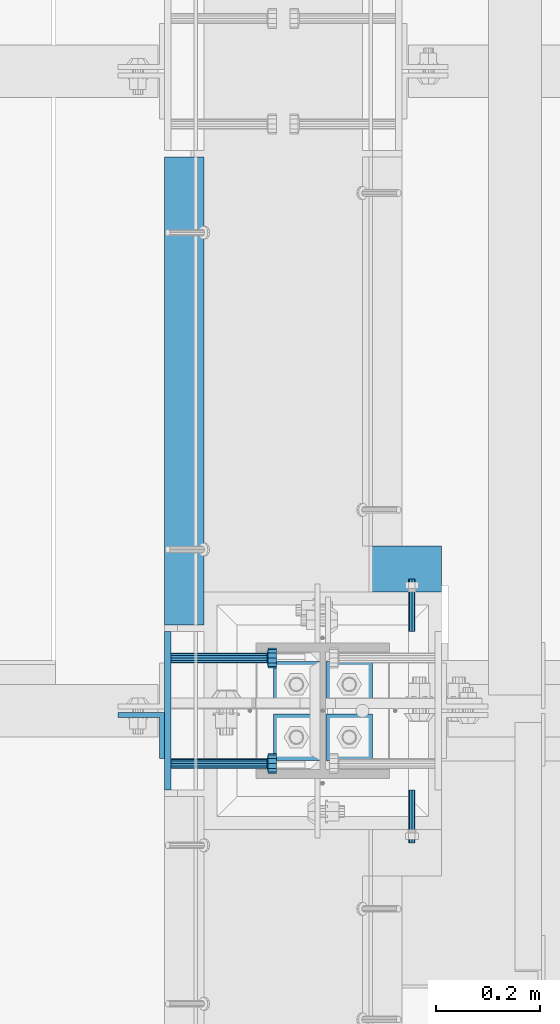
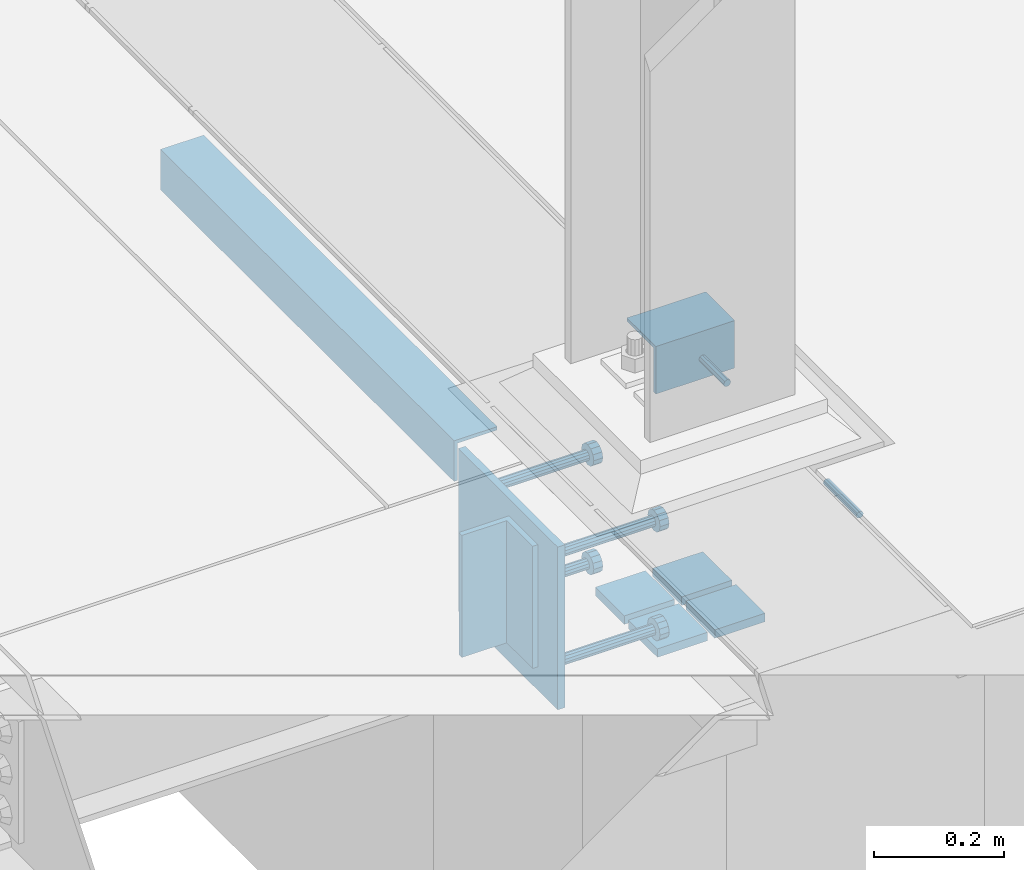
# One storey, part 2051 of 3843: 14 beams, 7 elements without a shape of their own.
"""IFC2X3 building model written with IfcOpenShell, lengths in millimetres."""

from ifc_helpers import new_model, si_unit, frame, origin_with_axes, place, context, subcontext, project, spatial, faceted_brep, material, type_object, element, aggregate, save


model = new_model("IFC2X3")

# Units and contexts
model_context = context("Model", 3, precision=1e-05, world=origin_with_axes())
body_context = subcontext(model_context, "Body", "Model", "MODEL_VIEW")
ifc_project = project(units=[si_unit("LENGTHUNIT", "METRE", prefix="MILLI"), si_unit("AREAUNIT", "SQUARE_METRE"), si_unit("VOLUMEUNIT", "CUBIC_METRE"), si_unit("MASSUNIT", "GRAM", prefix="KILO"), si_unit("TIMEUNIT", "SECOND"), si_unit("PLANEANGLEUNIT", "RADIAN"), si_unit("SOLIDANGLEUNIT", "STERADIAN"), si_unit("THERMODYNAMICTEMPERATUREUNIT", "DEGREE_CELSIUS"), si_unit("LUMINOUSINTENSITYUNIT", "LUMEN")], contexts=[model_context])

# Site, building, storey
site_placement = place(None, origin_with_axes())
site = spatial("IfcSite", under=ifc_project, at=site_placement, CompositionType="ELEMENT")
building_placement = place(site_placement, origin_with_axes())
building = spatial("IfcBuilding", under=site, at=building_placement, Name="Undefined", CompositionType="ELEMENT")
storey_placement = place(building_placement, origin_with_axes())
storey = spatial("IfcBuildingStorey", under=building, at=storey_placement, Name="Undefined", CompositionType="ELEMENT", Elevation=0.0)

# Assembly, beam
assembly_1_placement = place(storey_placement, origin_with_axes())
assembly_1 = element("IfcElementAssembly", 1, at=assembly_1_placement, inside=storey, Name="GRATING", AssemblyPlace="NOTDEFINED", PredefinedType="NOTDEFINED")
ifc_material_1 = material(Name="STEEL/A36")
beam_type_1 = type_object("IfcBeamType", Name="L3-1/2X3-1/2X1/4", PredefinedType="NOTDEFINED")
beam_1_placement = place(assembly_1_placement, frame((62725.3000467757, 15271.7501304977, 30384.7500045776), z_axis=(0.0, 0.0, -1.0), x_axis=(1.0, 0.0, 0.0)))
beam_1 = element("IfcBeam", 2, at=beam_1_placement, type_object=beam_type_1, material=ifc_material_1, Name="ANGLE", ObjectType="L3-1/2X3-1/2X1/4", context=body_context, shape_type="Brep", body=[
    faceted_brep([(-3.63797880709171e-12, 44.4499999999971, -44.4500000000007), (-3.63797880709171e-12, 44.4499999999971, 44.4500000000007), (139.699994826158, 44.4499999999043, 44.4500000000007), (139.699994826158, 44.4499999999043, -44.4500000000007), (-3.63797880709171e-11, 38.1000000000149, 44.4500000000007), (139.699994826165, 38.0999999999021, 44.4500000000007), (0.0, 38.0999999999985, -38.0999999999985), (139.699999999997, 38.0999999999985, -38.0999999999985), (4.36557456851006e-11, -44.4500000000226, -38.0999999999985), (139.699994826253, -44.4500000001353, -38.0999999999985), (3.63797880709171e-12, -44.4499999999971, -44.4500000000007), (139.699994826253, -44.4500000001353, -44.4500000000007)], [[[0, 1, 2, 3]], [[1, 4, 5, 2]], [[4, 6, 7, 5]], [[6, 8, 9, 7]], [[8, 10, 11, 9]], [[10, 0, 3, 11]], [[5, 7, 9, 11, 3, 2]], [[10, 8, 6, 4, 1, 0]]]),
])
aggregate(assembly_1, [beam_1])

assembly_2_placement = place(storey_placement, origin_with_axes())
assembly_2 = element("IfcElementAssembly", 3, at=assembly_2_placement, inside=storey, Name="EPOXY BOLT", AssemblyPlace="NOTDEFINED", PredefinedType="RIGID_FRAME")
ifc_material_2 = material(Name="STEEL/A307")
beam_type_2 = type_object("IfcBeamType", PredefinedType="NOTDEFINED")
beam_2_placement = place(assembly_2_placement, frame((62807.8501800578, 15252.7000607682, 30378.4), z_axis=(0.0, 0.0, -1.0), x_axis=(0.0, -1.0, 0.0)))
beam_2 = element("IfcBeam", 4, at=beam_2_placement, type_object=beam_type_2, material=ifc_material_2, Name="EPOXY BOLT", context=body_context, shape_type="Brep", body=[
    faceted_brep([(0.0, -6.3499999046162, 0.0), (0.0, -4.49012806053361, -4.49012806053361), (101.6, -4.49012806053361, -4.49012806053361), (101.6, -6.34999999999854, 0.0), (7.27595761418343e-12, -1.81898940354586e-12, -6.34999990463257), (101.6, 0.0, -6.34999999999854), (0.0, 4.49012806053361, -4.49012806053361), (101.6, 4.49012806053361, -4.49012806053361), (7.27595761418343e-12, 6.3499999046162, 0.0), (101.6, 6.34999999999854, 0.0), (0.0, 4.49012806053361, 4.49012806053361), (101.6, 4.49012806053361, 4.49012806053361), (7.27595761418343e-12, -1.81898940354586e-12, 6.34999990463257), (101.6, 0.0, 6.34999999999854), (0.0, -4.49012806053361, 4.49012806053361), (101.6, -4.49012806053361, 4.49012806053361)], [[[0, 1, 2, 3]], [[1, 4, 5, 2]], [[4, 6, 7, 5]], [[6, 8, 9, 7]], [[8, 10, 11, 9]], [[10, 12, 13, 11]], [[12, 14, 15, 13]], [[14, 0, 3, 15]], [[5, 7, 9, 11, 13, 15, 3, 2]], [[14, 12, 10, 8, 6, 4, 1, 0]]]),
])
aggregate(assembly_2, [beam_2])

assembly_3_placement = place(storey_placement, origin_with_axes())
assembly_3 = element("IfcElementAssembly", 5, at=assembly_3_placement, inside=storey, Name="EPOXY BOLT", AssemblyPlace="NOTDEFINED", PredefinedType="RIGID_FRAME")
beam_3_placement = place(assembly_3_placement, frame((62807.8501800578, 14744.6999392318, 30378.4), z_axis=(0.0, 0.0, -1.0), x_axis=(0.0, 1.0, 0.0)))
beam_3 = element("IfcBeam", 6, at=beam_3_placement, type_object=beam_type_2, material=ifc_material_2, Name="EPOXY BOLT", context=body_context, shape_type="Brep", body=[
    faceted_brep([(0.0, -6.3499999046162, 0.0), (0.0, -4.49012806053361, -4.49012806053361), (101.6, -4.49012806053361, -4.49012806053361), (101.6, -6.34999999999854, 0.0), (7.27595761418343e-12, -1.81898940354586e-12, -6.34999990463257), (101.6, 0.0, -6.34999999999854), (0.0, 4.49012806053361, -4.49012806053361), (101.6, 4.49012806053361, -4.49012806053361), (7.27595761418343e-12, 6.3499999046162, 0.0), (101.6, 6.34999999999854, 0.0), (0.0, 4.49012806053361, 4.49012806053361), (101.6, 4.49012806053361, 4.49012806053361), (7.27595761418343e-12, -1.81898940354586e-12, 6.34999990463257), (101.6, 0.0, 6.34999999999854), (0.0, -4.49012806053361, 4.49012806053361), (101.6, -4.49012806053361, 4.49012806053361)], [[[0, 1, 2, 3]], [[1, 4, 5, 2]], [[4, 6, 7, 5]], [[6, 8, 9, 7]], [[8, 10, 11, 9]], [[10, 12, 13, 11]], [[12, 14, 15, 13]], [[14, 0, 3, 15]], [[5, 7, 9, 11, 13, 15, 3, 2]], [[14, 12, 10, 8, 6, 4, 1, 0]]]),
])
aggregate(assembly_3, [beam_3])

assembly_4_placement = place(storey_placement, origin_with_axes())
assembly_4 = element("IfcElementAssembly", 7, at=assembly_4_placement, inside=storey, Name="EMBED PLATE", AssemblyPlace="NOTDEFINED", PredefinedType="RIGID_FRAME")
beam_type_3 = type_object("IfcBeamType", PredefinedType="NOTDEFINED")
beam_4_placement = place(assembly_4_placement, frame((62337.9499969482, 14998.7, 30422.85), z_axis=(0.0, -1.0, 0.0), x_axis=(0.0, 0.0, -1.0)))
beam_4 = element("IfcBeam", 8, at=beam_4_placement, type_object=beam_type_3, material=ifc_material_1, Name="EMBED PLATE", context=body_context, shape_type="Brep", body=[
    faceted_brep([(-1.0550138540566e-10, 6.34999999999854, -152.400000000664), (1.0550138540566e-10, 6.34999999999854, 152.400000000656), (304.799999999999, 6.34999999999854, 152.400000000001), (304.799999999999, 6.34999999999854, -152.400000000001), (1.0550138540566e-10, -6.34999999999854, 152.400000000656), (304.799999999999, -6.34999999999854, 152.400000000001), (-1.0550138540566e-10, -6.34999999999854, -152.400000000664), (304.799999999999, -6.34999999999854, -152.400000000001)], [[[0, 1, 2, 3]], [[1, 4, 5, 2]], [[4, 6, 7, 5]], [[6, 0, 3, 7]], [[5, 7, 3, 2]], [[6, 4, 1, 0]]]),
])

assembly_5_placement = place(storey_placement, origin_with_axes())
assembly_5 = element("IfcElementAssembly", 9, at=assembly_5_placement, inside=storey, Name="ANGLE", AssemblyPlace="NOTDEFINED", PredefinedType="RIGID_FRAME")
beam_type_4 = type_object("IfcBeamType", Name="L3X3X1/4", PredefinedType="NOTDEFINED")
beam_5_placement = place(assembly_5_placement, frame((62369.7000040825, 16063.9120001143, 30391.1000045777), z_axis=(0.0, 0.0, -1.0), x_axis=(0.0, -1.0, 0.0)))
beam_5 = element("IfcBeam", 10, at=beam_5_placement, type_object=beam_type_4, material=ifc_material_1, Name="ANGLE", ObjectType="L3X3X1/4", context=body_context, shape_type="Brep", body=[
    faceted_brep([(0.0, 38.0999999999985, -38.0999999999985), (0.0, 38.0999999999985, 38.0999999999985), (900.112000000037, 38.1000000023996, 38.0999999999985), (900.112000000037, 38.1000000023996, -38.0999999999985), (0.0, 31.75, 38.0999999999985), (900.11200000003, 31.7500000023938, 38.0999999999985), (0.0, 31.75, -31.75), (900.11200000003, 31.7500000023938, -31.75), (0.0, -38.0999999999985, -31.75), (900.111999999965, -38.0999999976048, -31.75), (0.0, -38.0999999999985, -38.0999999999985), (900.111999999965, -38.0999999976048, -38.0999999999985)], [[[0, 1, 2, 3]], [[1, 4, 5, 2]], [[4, 6, 7, 5]], [[6, 8, 9, 7]], [[8, 10, 11, 9]], [[10, 0, 3, 11]], [[5, 7, 9, 11, 3, 2]], [[10, 8, 6, 4, 1, 0]]]),
])
aggregate(assembly_5, [beam_5])

# Assembly, beams
assembly_6_placement = place(storey_placement, origin_with_axes())
assembly_6 = element("IfcElementAssembly", 11, at=assembly_6_placement, inside=storey, Name="TEMPLATE", AssemblyPlace="NOTDEFINED", PredefinedType="RIGID_FRAME")
ifc_material_3 = material(Name="STEEL/A572-50")
beam_type_5 = type_object("IfcBeamType", PredefinedType="NOTDEFINED")
beam_6_placement = place(assembly_6_placement, frame((62585.6, 14903.45, 30116.4625), z_axis=(1.0, 0.0, 0.0), x_axis=(0.0, 1.0, 0.0)))
beam_6 = element("IfcBeam", 12, at=beam_6_placement, type_object=beam_type_5, material=ifc_material_3, context=body_context, shape_type="Brep", body=[
    faceted_brep([(0.0, 7.9375, -44.4499999999971), (0.0, 7.9375, 44.4499999999971), (88.8999999999942, 7.9375, 44.4499999999971), (88.8999999999942, 7.9375, -44.4499999999971), (0.0, -7.9375, 44.4499999999971), (88.8999999999942, -7.9375, 44.4499999999971), (0.0, -7.9375, -44.4499999999971), (88.8999999999942, -7.9375, -44.4499999999971)], [[[0, 1, 2, 3]], [[1, 4, 5, 2]], [[4, 6, 7, 5]], [[6, 0, 3, 7]], [[5, 7, 3, 2]], [[6, 4, 1, 0]]]),
])
beam_7_placement = place(assembly_6_placement, frame((62687.2, 14903.45, 30116.4625), z_axis=(1.0, 0.0, 0.0), x_axis=(0.0, 1.0, 0.0)))
beam_7 = element("IfcBeam", 13, at=beam_7_placement, type_object=beam_type_5, material=ifc_material_3, context=body_context, shape_type="Brep", body=[
    faceted_brep([(0.0, 7.9375, -44.4499999999971), (0.0, 7.9375, 44.4499999999971), (88.8999999999942, 7.9375, 44.4499999999971), (88.8999999999942, 7.9375, -44.4499999999971), (0.0, -7.9375, 44.4499999999971), (88.8999999999942, -7.9375, 44.4499999999971), (0.0, -7.9375, -44.4499999999971), (88.8999999999942, -7.9375, -44.4499999999971)], [[[0, 1, 2, 3]], [[1, 4, 5, 2]], [[4, 6, 7, 5]], [[6, 0, 3, 7]], [[5, 7, 3, 2]], [[6, 4, 1, 0]]]),
])
beam_8_placement = place(assembly_6_placement, frame((62585.6, 15005.05, 30116.4625), z_axis=(1.0, 0.0, 0.0), x_axis=(0.0, 1.0, 0.0)))
beam_8 = element("IfcBeam", 14, at=beam_8_placement, type_object=beam_type_5, material=ifc_material_3, context=body_context, shape_type="Brep", body=[
    faceted_brep([(0.0, 7.9375, -44.4499999999971), (0.0, 7.9375, 44.4499999999971), (88.8999999999942, 7.9375, 44.4499999999971), (88.8999999999942, 7.9375, -44.4499999999971), (0.0, -7.9375, 44.4499999999971), (88.8999999999942, -7.9375, 44.4499999999971), (0.0, -7.9375, -44.4499999999971), (88.8999999999942, -7.9375, -44.4499999999971)], [[[0, 1, 2, 3]], [[1, 4, 5, 2]], [[4, 6, 7, 5]], [[6, 0, 3, 7]], [[5, 7, 3, 2]], [[6, 4, 1, 0]]]),
])
beam_9_placement = place(assembly_6_placement, frame((62687.2, 15005.05, 30116.4625), z_axis=(1.0, 0.0, 0.0), x_axis=(0.0, 1.0, 0.0)))
beam_9 = element("IfcBeam", 15, at=beam_9_placement, type_object=beam_type_5, material=ifc_material_3, context=body_context, shape_type="Brep", body=[
    faceted_brep([(0.0, 7.9375, -44.4499999999971), (0.0, 7.9375, 44.4499999999971), (88.8999999999942, 7.9375, 44.4499999999971), (88.8999999999942, 7.9375, -44.4499999999971), (0.0, -7.9375, 44.4499999999971), (88.8999999999942, -7.9375, 44.4499999999971), (0.0, -7.9375, -44.4499999999971), (88.8999999999942, -7.9375, -44.4499999999971)], [[[0, 1, 2, 3]], [[1, 4, 5, 2]], [[4, 6, 7, 5]], [[6, 0, 3, 7]], [[5, 7, 3, 2]], [[6, 4, 1, 0]]]),
])
aggregate(assembly_6, [beam_6, beam_7, beam_8, beam_9])

# Assembly, beam
assembly_7_placement = place(storey_placement, origin_with_axes())
assembly_7 = element("IfcElementAssembly", 16, at=assembly_7_placement, inside=storey, Name="BEAM", AssemblyPlace="NOTDEFINED", PredefinedType="RIGID_FRAME")
beam_type_6 = type_object("IfcBeamType", Name="L3-1/2X3-1/2X3/8", PredefinedType="NOTDEFINED")
beam_10_placement = place(assembly_7_placement, frame((62287.1499969482, 14951.075, 30391.1), z_axis=(0.0, -1.0, 0.0), x_axis=(0.0, 0.0, -1.0)))
beam_10 = element("IfcBeam", 17, at=beam_10_placement, type_object=beam_type_6, material=ifc_material_1, Name="ANGLE", ObjectType="L3-1/2X3-1/2X3/8", context=body_context, shape_type="Brep", body=[
    faceted_brep([(-3.63797880709171e-12, 44.4499999999971, -44.4500000000007), (-3.63797880709171e-12, 44.4499999999971, 44.4500000000007), (228.600000000006, 44.4499999999971, 44.4500000000007), (228.600000000006, 44.4499999999971, -44.4500000000007), (0.0, 34.9250000000029, 44.4500000000007), (228.600000000006, 34.9250000000029, 44.4500000000007), (0.0, 34.9250000000029, -34.9250000000029), (228.600000000006, 34.9250000000029, -34.9249999999993), (0.0, -44.4499999999971, -34.9249999999993), (228.600000000006, -44.4499999999971, -34.9249999999993), (3.63797880709171e-12, -44.4499999999971, -44.4500000000007), (228.600000000006, -44.4499999999971, -44.4500000000007)], [[[0, 1, 2, 3]], [[1, 4, 5, 2]], [[4, 6, 7, 5]], [[6, 8, 9, 7]], [[8, 10, 11, 9]], [[10, 0, 3, 11]], [[5, 7, 9, 11, 3, 2]], [[10, 8, 6, 4, 1, 0]]]),
])
aggregate(assembly_7, [beam_10])

# Beam
ifc_material_4 = material(Name="STEEL/A108")
beam_type_7 = type_object("IfcBeamType", PredefinedType="NOTDEFINED")
beam_11_placement = place(assembly_4_placement, frame((62344.2999969482, 15100.3, 30372.05), z_axis=(0.0, 1.0, 0.0), x_axis=(1.0, 0.0, 0.0)))
beam_11 = element("IfcBeam", 18, at=beam_11_placement, type_object=beam_type_7, material=ifc_material_4, Name="HEADED STUD ANCHOR", context=body_context, shape_type="Brep", body=[
    faceted_brep([(0.0, -9.52000045776367, 0.0), (0.0, -8.25, -4.76000022888184), (184.912000000004, -8.25, -4.76000022888184), (184.912000000004, -9.52000045776367, 0.0), (0.0, -4.76000022888184, -8.25), (184.912000000004, -4.76000022888184, -8.25), (0.0, 0.0, -9.52000045776367), (184.912000000004, 0.0, -9.52000045776367), (0.0, 4.76000022888184, -8.25), (184.912000000004, 4.76000022888184, -8.25), (0.0, 8.25, -4.76000022888184), (184.912000000004, 8.25, -4.76000022888184), (0.0, 9.52000045776367, 0.0), (184.912000000004, 9.52000045776367, 0.0), (0.0, 8.25, 4.76000022888184), (184.912000000004, 8.25, 4.76000022888184), (0.0, 4.76000022888184, 8.25), (184.912000000004, 4.76000022888184, 8.25), (0.0, 0.0, 9.52000045776367), (184.912000000004, 0.0, 9.52000045776367), (0.0, -4.76000022888184, 8.25), (184.912000000004, -4.76000022888184, 8.25), (0.0, -8.25, 4.76000022888184), (184.912000000004, -8.25, 4.76000022888184), (186.944000000003, -16.5, -9.52000045776367), (186.944000000003, -19.0499992370605, 0.0), (186.944000000003, -9.52000045776367, -16.5), (186.944000000003, 0.0, -19.0499992370605), (186.944000000003, 9.52000045776367, -16.5), (186.944000000003, 16.5, -9.52000045776367), (186.944000000003, 19.0499992370605, 0.0), (186.944000000003, 16.5, 9.52000045776367), (186.944000000003, 9.52000045776367, 16.5), (186.944000000003, 0.0, 19.0499992370605), (186.944000000003, -9.52000045776367, 16.5), (186.944000000003, -16.5, 9.52000045776367), (203.199999999997, -16.5, -9.52000045776367), (203.199999999997, -19.0499992370605, 0.0), (203.199999999997, -9.52000045776367, -16.5), (203.199999999997, 0.0, -19.0499992370605), (203.199999999997, 9.52000045776367, -16.5), (203.199999999997, 16.5, -9.52000045776367), (203.199999999997, 19.0499992370605, 0.0), (203.199999999997, 16.5, 9.52000045776367), (203.199999999997, 9.52000045776367, 16.5), (203.199999999997, 0.0, 19.0499992370605), (203.199999999997, -9.52000045776367, 16.5), (203.199999999997, -16.5, 9.52000045776367)], [[[0, 1, 2, 3]], [[1, 4, 5, 2]], [[4, 6, 7, 5]], [[6, 8, 9, 7]], [[8, 10, 11, 9]], [[10, 12, 13, 11]], [[12, 14, 15, 13]], [[14, 16, 17, 15]], [[16, 18, 19, 17]], [[18, 20, 21, 19]], [[20, 22, 23, 21]], [[22, 0, 3, 23]], [[22, 20, 18, 16, 14, 12, 10, 8, 6, 4, 1, 0]], [[3, 2, 24, 25]], [[2, 5, 26, 24]], [[5, 7, 27, 26]], [[7, 9, 28, 27]], [[9, 11, 29, 28]], [[11, 13, 30, 29]], [[13, 15, 31, 30]], [[15, 17, 32, 31]], [[17, 19, 33, 32]], [[19, 21, 34, 33]], [[21, 23, 35, 34]], [[23, 3, 25, 35]], [[25, 24, 36, 37]], [[24, 26, 38, 36]], [[26, 27, 39, 38]], [[27, 28, 40, 39]], [[28, 29, 41, 40]], [[29, 30, 42, 41]], [[30, 31, 43, 42]], [[31, 32, 44, 43]], [[32, 33, 45, 44]], [[33, 34, 46, 45]], [[34, 35, 47, 46]], [[35, 25, 37, 47]], [[38, 39, 40, 41, 42, 43, 44, 45, 46, 47, 37, 36]]]),
])

beam_12_placement = place(assembly_4_placement, frame((62344.2999969482, 15100.3, 30168.85), z_axis=(0.0, 1.0, 0.0), x_axis=(1.0, 0.0, 0.0)))
beam_12 = element("IfcBeam", 19, at=beam_12_placement, type_object=beam_type_7, material=ifc_material_4, Name="HEADED STUD ANCHOR", context=body_context, shape_type="Brep", body=[
    faceted_brep([(0.0, -9.52000045776367, 0.0), (0.0, -8.25, -4.76000022888184), (184.912000000004, -8.25, -4.76000022888184), (184.912000000004, -9.52000045776367, 0.0), (0.0, -4.76000022888184, -8.25), (184.912000000004, -4.76000022888184, -8.25), (0.0, 0.0, -9.52000045776367), (184.912000000004, 0.0, -9.52000045776367), (0.0, 4.76000022888184, -8.25), (184.912000000004, 4.76000022888184, -8.25), (0.0, 8.25, -4.76000022888184), (184.912000000004, 8.25, -4.76000022888184), (0.0, 9.52000045776367, 0.0), (184.912000000004, 9.52000045776367, 0.0), (0.0, 8.25, 4.76000022888184), (184.912000000004, 8.25, 4.76000022888184), (0.0, 4.76000022888184, 8.25), (184.912000000004, 4.76000022888184, 8.25), (0.0, 0.0, 9.52000045776367), (184.912000000004, 0.0, 9.52000045776367), (0.0, -4.76000022888184, 8.25), (184.912000000004, -4.76000022888184, 8.25), (0.0, -8.25, 4.76000022888184), (184.912000000004, -8.25, 4.76000022888184), (186.944000000003, -16.5, -9.52000045776367), (186.944000000003, -19.0499992370605, 0.0), (186.944000000003, -9.52000045776367, -16.5), (186.944000000003, 0.0, -19.0499992370605), (186.944000000003, 9.52000045776367, -16.5), (186.944000000003, 16.5, -9.52000045776367), (186.944000000003, 19.0499992370605, 0.0), (186.944000000003, 16.5, 9.52000045776367), (186.944000000003, 9.52000045776367, 16.5), (186.944000000003, 0.0, 19.0499992370605), (186.944000000003, -9.52000045776367, 16.5), (186.944000000003, -16.5, 9.52000045776367), (203.199999999997, -16.5, -9.52000045776367), (203.199999999997, -19.0499992370605, 0.0), (203.199999999997, -9.52000045776367, -16.5), (203.199999999997, 0.0, -19.0499992370605), (203.199999999997, 9.52000045776367, -16.5), (203.199999999997, 16.5, -9.52000045776367), (203.199999999997, 19.0499992370605, 0.0), (203.199999999997, 16.5, 9.52000045776367), (203.199999999997, 9.52000045776367, 16.5), (203.199999999997, 0.0, 19.0499992370605), (203.199999999997, -9.52000045776367, 16.5), (203.199999999997, -16.5, 9.52000045776367)], [[[0, 1, 2, 3]], [[1, 4, 5, 2]], [[4, 6, 7, 5]], [[6, 8, 9, 7]], [[8, 10, 11, 9]], [[10, 12, 13, 11]], [[12, 14, 15, 13]], [[14, 16, 17, 15]], [[16, 18, 19, 17]], [[18, 20, 21, 19]], [[20, 22, 23, 21]], [[22, 0, 3, 23]], [[22, 20, 18, 16, 14, 12, 10, 8, 6, 4, 1, 0]], [[3, 2, 24, 25]], [[2, 5, 26, 24]], [[5, 7, 27, 26]], [[7, 9, 28, 27]], [[9, 11, 29, 28]], [[11, 13, 30, 29]], [[13, 15, 31, 30]], [[15, 17, 32, 31]], [[17, 19, 33, 32]], [[19, 21, 34, 33]], [[21, 23, 35, 34]], [[23, 3, 25, 35]], [[25, 24, 36, 37]], [[24, 26, 38, 36]], [[26, 27, 39, 38]], [[27, 28, 40, 39]], [[28, 29, 41, 40]], [[29, 30, 42, 41]], [[30, 31, 43, 42]], [[31, 32, 44, 43]], [[32, 33, 45, 44]], [[33, 34, 46, 45]], [[34, 35, 47, 46]], [[35, 25, 37, 47]], [[38, 39, 40, 41, 42, 43, 44, 45, 46, 47, 37, 36]]]),
])

beam_13_placement = place(assembly_4_placement, frame((62344.2999969482, 14897.1, 30372.05), z_axis=(0.0, 1.0, 0.0), x_axis=(1.0, 0.0, 0.0)))
beam_13 = element("IfcBeam", 20, at=beam_13_placement, type_object=beam_type_7, material=ifc_material_1, Name="PLATE", context=body_context, shape_type="Brep", body=[
    faceted_brep([(0.0, -9.52000045776367, 0.0), (0.0, -8.25, -4.76000022888184), (184.912000000004, -8.25, -4.76000022888184), (184.912000000004, -9.52000045776367, 0.0), (0.0, -4.76000022888184, -8.25), (184.912000000004, -4.76000022888184, -8.25), (0.0, 0.0, -9.52000045776367), (184.912000000004, 0.0, -9.52000045776367), (0.0, 4.76000022888184, -8.25), (184.912000000004, 4.76000022888184, -8.25), (0.0, 8.25, -4.76000022888184), (184.912000000004, 8.25, -4.76000022888184), (0.0, 9.52000045776367, 0.0), (184.912000000004, 9.52000045776367, 0.0), (0.0, 8.25, 4.76000022888184), (184.912000000004, 8.25, 4.76000022888184), (0.0, 4.76000022888184, 8.25), (184.912000000004, 4.76000022888184, 8.25), (0.0, 0.0, 9.52000045776367), (184.912000000004, 0.0, 9.52000045776367), (0.0, -4.76000022888184, 8.25), (184.912000000004, -4.76000022888184, 8.25), (0.0, -8.25, 4.76000022888184), (184.912000000004, -8.25, 4.76000022888184), (186.944000000003, -16.5, -9.52000045776367), (186.944000000003, -19.0499992370605, 0.0), (186.944000000003, -9.52000045776367, -16.5), (186.944000000003, 0.0, -19.0499992370605), (186.944000000003, 9.52000045776367, -16.5), (186.944000000003, 16.5, -9.52000045776367), (186.944000000003, 19.0499992370605, 0.0), (186.944000000003, 16.5, 9.52000045776367), (186.944000000003, 9.52000045776367, 16.5), (186.944000000003, 0.0, 19.0499992370605), (186.944000000003, -9.52000045776367, 16.5), (186.944000000003, -16.5, 9.52000045776367), (203.199999999997, -16.5, -9.52000045776367), (203.199999999997, -19.0499992370605, 0.0), (203.199999999997, -9.52000045776367, -16.5), (203.199999999997, 0.0, -19.0499992370605), (203.199999999997, 9.52000045776367, -16.5), (203.199999999997, 16.5, -9.52000045776367), (203.199999999997, 19.0499992370605, 0.0), (203.199999999997, 16.5, 9.52000045776367), (203.199999999997, 9.52000045776367, 16.5), (203.199999999997, 0.0, 19.0499992370605), (203.199999999997, -9.52000045776367, 16.5), (203.199999999997, -16.5, 9.52000045776367)], [[[0, 1, 2, 3]], [[1, 4, 5, 2]], [[4, 6, 7, 5]], [[6, 8, 9, 7]], [[8, 10, 11, 9]], [[10, 12, 13, 11]], [[12, 14, 15, 13]], [[14, 16, 17, 15]], [[16, 18, 19, 17]], [[18, 20, 21, 19]], [[20, 22, 23, 21]], [[22, 0, 3, 23]], [[22, 20, 18, 16, 14, 12, 10, 8, 6, 4, 1, 0]], [[3, 2, 24, 25]], [[2, 5, 26, 24]], [[5, 7, 27, 26]], [[7, 9, 28, 27]], [[9, 11, 29, 28]], [[11, 13, 30, 29]], [[13, 15, 31, 30]], [[15, 17, 32, 31]], [[17, 19, 33, 32]], [[19, 21, 34, 33]], [[21, 23, 35, 34]], [[23, 3, 25, 35]], [[25, 24, 36, 37]], [[24, 26, 38, 36]], [[26, 27, 39, 38]], [[27, 28, 40, 39]], [[28, 29, 41, 40]], [[29, 30, 42, 41]], [[30, 31, 43, 42]], [[31, 32, 44, 43]], [[32, 33, 45, 44]], [[33, 34, 46, 45]], [[34, 35, 47, 46]], [[35, 25, 37, 47]], [[38, 39, 40, 41, 42, 43, 44, 45, 46, 47, 37, 36]]]),
])

beam_14_placement = place(assembly_4_placement, frame((62344.2999969482, 14897.1, 30168.85), z_axis=(0.0, 1.0, 0.0), x_axis=(1.0, 0.0, 0.0)))
beam_14 = element("IfcBeam", 21, at=beam_14_placement, type_object=beam_type_7, material=ifc_material_4, Name="HEADED STUD ANCHOR", context=body_context, shape_type="Brep", body=[
    faceted_brep([(0.0, -9.52000045776367, 0.0), (0.0, -8.25, -4.76000022888184), (184.912000000004, -8.25, -4.76000022888184), (184.912000000004, -9.52000045776367, 0.0), (0.0, -4.76000022888184, -8.25), (184.912000000004, -4.76000022888184, -8.25), (0.0, 0.0, -9.52000045776367), (184.912000000004, 0.0, -9.52000045776367), (0.0, 4.76000022888184, -8.25), (184.912000000004, 4.76000022888184, -8.25), (0.0, 8.25, -4.76000022888184), (184.912000000004, 8.25, -4.76000022888184), (0.0, 9.52000045776367, 0.0), (184.912000000004, 9.52000045776367, 0.0), (0.0, 8.25, 4.76000022888184), (184.912000000004, 8.25, 4.76000022888184), (0.0, 4.76000022888184, 8.25), (184.912000000004, 4.76000022888184, 8.25), (0.0, 0.0, 9.52000045776367), (184.912000000004, 0.0, 9.52000045776367), (0.0, -4.76000022888184, 8.25), (184.912000000004, -4.76000022888184, 8.25), (0.0, -8.25, 4.76000022888184), (184.912000000004, -8.25, 4.76000022888184), (186.944000000003, -16.5, -9.52000045776367), (186.944000000003, -19.0499992370605, 0.0), (186.944000000003, -9.52000045776367, -16.5), (186.944000000003, 0.0, -19.0499992370605), (186.944000000003, 9.52000045776367, -16.5), (186.944000000003, 16.5, -9.52000045776367), (186.944000000003, 19.0499992370605, 0.0), (186.944000000003, 16.5, 9.52000045776367), (186.944000000003, 9.52000045776367, 16.5), (186.944000000003, 0.0, 19.0499992370605), (186.944000000003, -9.52000045776367, 16.5), (186.944000000003, -16.5, 9.52000045776367), (203.199999999997, -16.5, -9.52000045776367), (203.199999999997, -19.0499992370605, 0.0), (203.199999999997, -9.52000045776367, -16.5), (203.199999999997, 0.0, -19.0499992370605), (203.199999999997, 9.52000045776367, -16.5), (203.199999999997, 16.5, -9.52000045776367), (203.199999999997, 19.0499992370605, 0.0), (203.199999999997, 16.5, 9.52000045776367), (203.199999999997, 9.52000045776367, 16.5), (203.199999999997, 0.0, 19.0499992370605), (203.199999999997, -9.52000045776367, 16.5), (203.199999999997, -16.5, 9.52000045776367)], [[[0, 1, 2, 3]], [[1, 4, 5, 2]], [[4, 6, 7, 5]], [[6, 8, 9, 7]], [[8, 10, 11, 9]], [[10, 12, 13, 11]], [[12, 14, 15, 13]], [[14, 16, 17, 15]], [[16, 18, 19, 17]], [[18, 20, 21, 19]], [[20, 22, 23, 21]], [[22, 0, 3, 23]], [[22, 20, 18, 16, 14, 12, 10, 8, 6, 4, 1, 0]], [[3, 2, 24, 25]], [[2, 5, 26, 24]], [[5, 7, 27, 26]], [[7, 9, 28, 27]], [[9, 11, 29, 28]], [[11, 13, 30, 29]], [[13, 15, 31, 30]], [[15, 17, 32, 31]], [[17, 19, 33, 32]], [[19, 21, 34, 33]], [[21, 23, 35, 34]], [[23, 3, 25, 35]], [[25, 24, 36, 37]], [[24, 26, 38, 36]], [[26, 27, 39, 38]], [[27, 28, 40, 39]], [[28, 29, 41, 40]], [[29, 30, 42, 41]], [[30, 31, 43, 42]], [[31, 32, 44, 43]], [[32, 33, 45, 44]], [[33, 34, 46, 45]], [[34, 35, 47, 46]], [[35, 25, 37, 47]], [[38, 39, 40, 41, 42, 43, 44, 45, 46, 47, 37, 36]]]),
])

aggregate(assembly_4, [beam_11, beam_12, beam_13, beam_14, beam_4])

save(model, "model.ifc")
